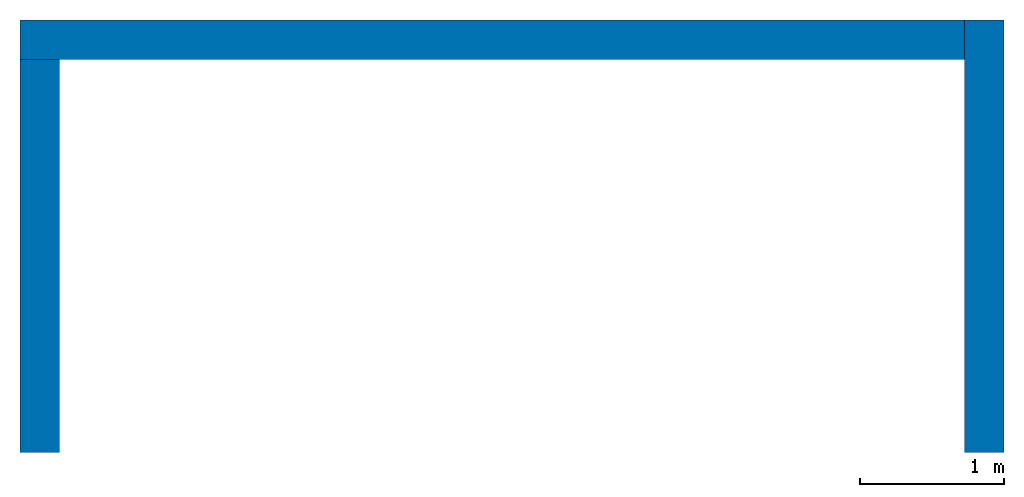
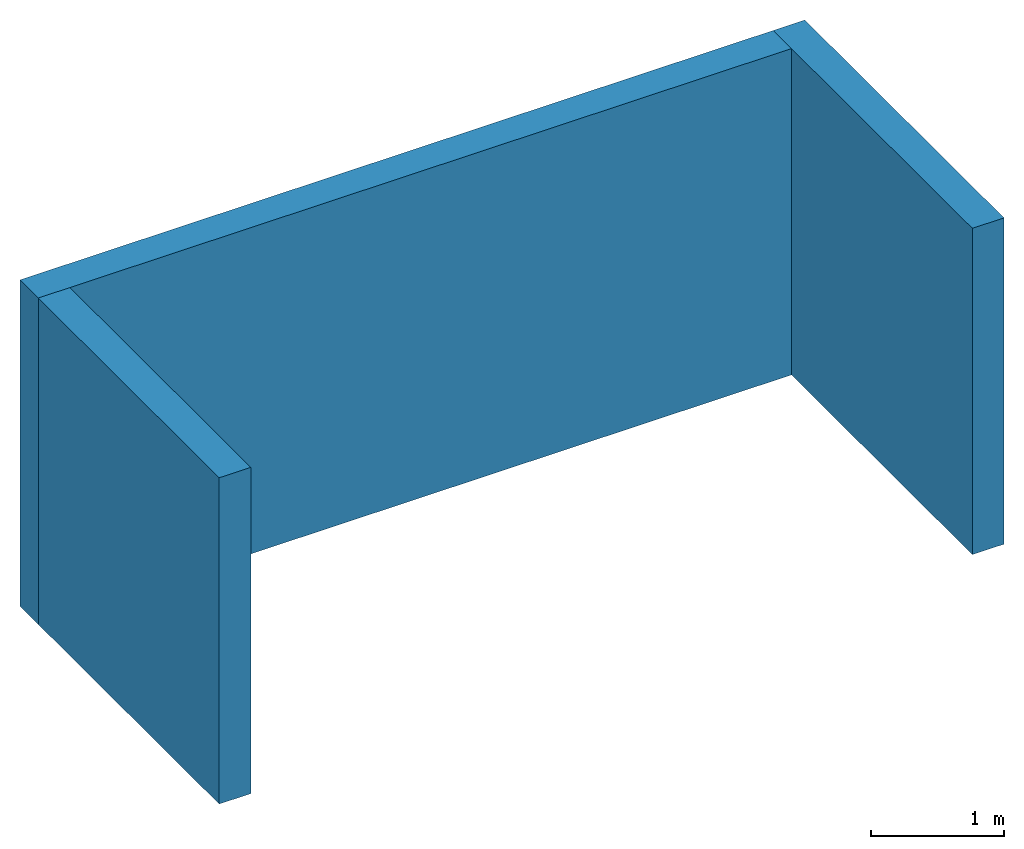
# Not in any storey: 3 walls.
"""IFC4 model written with IfcOpenShell, lengths in metres."""

from ifc_helpers import new_model, entity, si_unit, converted_unit, frame, origin_with_axes, origin_2d_with_axis, place, context, subcontext, project, indexed_curve, outline, extrude, material, layer, layer_set, layer_usage, type_object, element, save


model = new_model("IFC4")

# Units and contexts
model_context = context("Model", 3, precision=1e-05, world=origin_with_axes())
plan_context = context("Plan", 2, precision=1e-05, world=origin_2d_with_axis())
body_context = subcontext(model_context, "Body", "Model", "MODEL_VIEW")
ifc_project = project(units=[si_unit("LENGTHUNIT", "METRE"), converted_unit("PLANEANGLEUNIT", "degree", entity("IfcReal", 0.0174532925199433), si_unit("PLANEANGLEUNIT", "RADIAN"), dimensions=[0, 0, 0, 0, 0, 0, 0]), si_unit("AREAUNIT", "SQUARE_METRE"), si_unit("VOLUMEUNIT", "CUBIC_METRE")], contexts=[model_context, plan_context])

# Walls
ifc_material = material()
ifc_layer_1 = layer(ifc_material, 0.100000001490116, Name="Stone")
ifc_layer_2 = layer(ifc_material, 0.0750000029802322, Name="cavity")
ifc_layer_3 = layer(ifc_material, 0.100000001490116, Name="Blockwork")
ifc_layer_set = layer_set([ifc_layer_1, ifc_layer_2, ifc_layer_3])
ifc_layer_usage_1 = layer_usage(ifc_layer_set, "AXIS2", "POSITIVE", 0.0)
wall_type = type_object("IfcWallType", Name="External wall", PredefinedType="STANDARD", material=ifc_layer_set)
wall_1_placement = place(None, frame((1.27500104904175, 8.44999980926514, 0.0), z_axis=(0.0, 0.0, 1.0), x_axis=(3.13916473260163e-07, 0.999999999999951, 0.0)))
element("IfcWall", 1, at=wall_1_placement, type_object=wall_type, material=ifc_layer_usage_1, Name="Wall", context=body_context, shape_type="SweptSolid", body=[
    extrude(outline(indexed_curve([(0.0, 0.0), (0.0, 0.275000005960464), (3.00000000000015, 0.275000005960464), (3.00000000000015, 0.0), (0.0, 0.0)], self_intersect=False)), origin_with_axes(), (0.0, 0.0, 1.0), 3.0),
])
ifc_layer_usage_2 = layer_usage(ifc_layer_set, "AXIS2", "POSITIVE", 0.0)
wall_2_placement = place(None, frame((1.00000202655792, 11.4499998092651, 0.0), z_axis=(0.0, 0.0, 1.0), x_axis=(-0.999999999999924, 3.89414367418765e-07, 0.0)))
element("IfcWall", 2, at=wall_2_placement, type_object=wall_type, material=ifc_layer_usage_2, Name="Wall", context=body_context, shape_type="SweptSolid", body=[
    extrude(outline(indexed_curve([(0.0, 0.0), (0.0, 0.275000005960464), (6.55000030284647, 0.275000005960464), (6.55000030284647, 0.0), (0.0, 0.0)], self_intersect=False)), origin_with_axes(), (0.0, 0.0, 1.0), 3.0),
])
ifc_layer_usage_3 = layer_usage(ifc_layer_set, "AXIS2", "POSITIVE", 0.0)
wall_3_placement = place(None, frame((-5.27499914169312, 8.44999885559082, 0.0), z_axis=(0.0, 0.0, 1.0), x_axis=(3.13916473260163e-07, 0.999999999999951, 0.0)))
element("IfcWall", 3, at=wall_3_placement, type_object=wall_type, material=ifc_layer_usage_3, Name="Wall", context=body_context, shape_type="SweptSolid", body=[
    extrude(outline(indexed_curve([(0.0, 0.0), (0.0, 0.275000005960464), (2.72500320924359, 0.275000005960464), (2.72500320924359, 0.0), (0.0, 0.0)], self_intersect=False)), origin_with_axes(), (0.0, 0.0, 1.0), 3.0),
])

save(model, "model.ifc")
